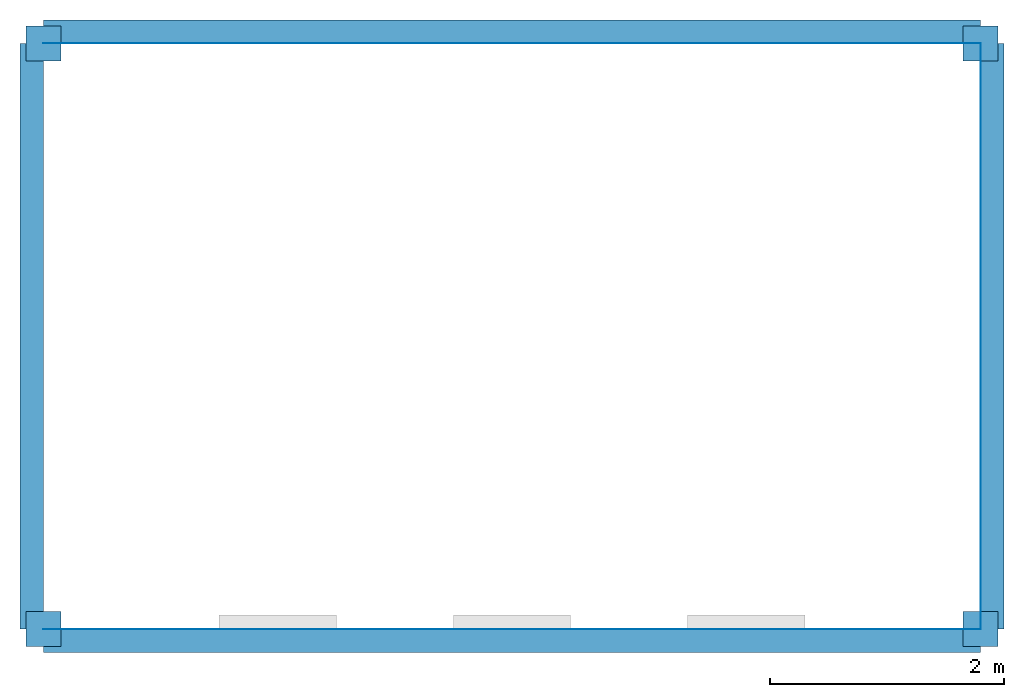
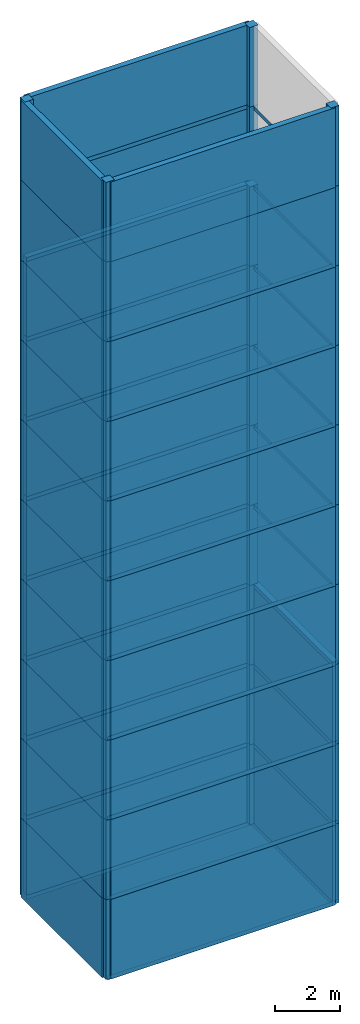
# Not in any storey, part 1 of 3: 40 columns, 33 walls, 10 slabs.
"""IFC4 model written with IfcOpenShell, lengths in metres."""

from ifc_helpers import new_model, si_unit, origin_with_axes, place, context, project, open_shell, faceted_brep, surface_model, element, save


model = new_model("IFC4")

# Units and contexts
model_context = context("Model", 3, precision=1e-05, world=origin_with_axes())
ifc_project = project(units=[si_unit("LENGTHUNIT", "METRE"), si_unit("AREAUNIT", "SQUARE_METRE"), si_unit("VOLUMEUNIT", "CUBIC_METRE")], contexts=[model_context])

# Columns
column_1_placement = place(None, origin_with_axes())
element("IfcColumn", 1, at=column_1_placement, context=model_context, shape_type="Brep", body=[
    faceted_brep([(-0.15, -0.15, 0.0), (-0.15, 0.15, 0.0), (0.15, 0.15, 0.0), (0.15, -0.15, 0.0), (-0.15, -0.15, 3.0), (0.15, -0.15, 3.0), (0.15, 0.15, 3.0), (-0.15, 0.15, 3.0)], [[[0, 1, 2, 3]], [[4, 5, 6, 7]], [[0, 3, 5, 4]], [[1, 7, 6, 2]], [[0, 4, 7, 1]], [[3, 2, 6, 5]]]),
])
column_2_placement = place(None, origin_with_axes())
element("IfcColumn", 2, at=column_2_placement, context=model_context, shape_type="Brep", body=[
    faceted_brep([(7.85, -0.15, 0.0), (7.85, 0.15, 0.0), (8.15, 0.15, 0.0), (8.15, -0.15, 0.0), (7.85, -0.15, 3.0), (8.15, -0.15, 3.0), (8.15, 0.15, 3.0), (7.85, 0.15, 3.0)], [[[0, 1, 2, 3]], [[4, 5, 6, 7]], [[0, 3, 5, 4]], [[1, 7, 6, 2]], [[0, 4, 7, 1]], [[3, 2, 6, 5]]]),
])
column_3_placement = place(None, origin_with_axes())
element("IfcColumn", 3, at=column_3_placement, context=model_context, shape_type="Brep", body=[
    faceted_brep([(7.85, 4.85, 0.0), (7.85, 5.15, 0.0), (8.15, 5.15, 0.0), (8.15, 4.85, 0.0), (7.85, 4.85, 3.0), (8.15, 4.85, 3.0), (8.15, 5.15, 3.0), (7.85, 5.15, 3.0)], [[[0, 1, 2, 3]], [[4, 5, 6, 7]], [[0, 3, 5, 4]], [[1, 7, 6, 2]], [[0, 4, 7, 1]], [[3, 2, 6, 5]]]),
])
column_4_placement = place(None, origin_with_axes())
element("IfcColumn", 4, at=column_4_placement, context=model_context, shape_type="Brep", body=[
    faceted_brep([(-0.15, 4.85, 0.0), (-0.15, 5.15, 0.0), (0.15, 5.15, 0.0), (0.15, 4.85, 0.0), (-0.15, 4.85, 3.0), (0.15, 4.85, 3.0), (0.15, 5.15, 3.0), (-0.15, 5.15, 3.0)], [[[0, 1, 2, 3]], [[4, 5, 6, 7]], [[0, 3, 5, 4]], [[1, 7, 6, 2]], [[0, 4, 7, 1]], [[3, 2, 6, 5]]]),
])
column_5_placement = place(None, origin_with_axes())
element("IfcColumn", 5, at=column_5_placement, context=model_context, shape_type="Brep", body=[
    faceted_brep([(-0.15, -0.15, 3.0), (-0.15, 0.15, 3.0), (0.15, 0.15, 3.0), (0.15, -0.15, 3.0), (-0.15, -0.15, 6.0), (0.15, -0.15, 6.0), (0.15, 0.15, 6.0), (-0.15, 0.15, 6.0)], [[[0, 1, 2, 3]], [[4, 5, 6, 7]], [[0, 3, 5, 4]], [[1, 7, 6, 2]], [[0, 4, 7, 1]], [[3, 2, 6, 5]]]),
])
column_6_placement = place(None, origin_with_axes())
element("IfcColumn", 6, at=column_6_placement, context=model_context, shape_type="Brep", body=[
    faceted_brep([(7.85, -0.15, 3.0), (7.85, 0.15, 3.0), (8.15, 0.15, 3.0), (8.15, -0.15, 3.0), (7.85, -0.15, 6.0), (8.15, -0.15, 6.0), (8.15, 0.15, 6.0), (7.85, 0.15, 6.0)], [[[0, 1, 2, 3]], [[4, 5, 6, 7]], [[0, 3, 5, 4]], [[1, 7, 6, 2]], [[0, 4, 7, 1]], [[3, 2, 6, 5]]]),
])
column_7_placement = place(None, origin_with_axes())
element("IfcColumn", 7, at=column_7_placement, context=model_context, shape_type="Brep", body=[
    faceted_brep([(7.85, 4.85, 3.0), (7.85, 5.15, 3.0), (8.15, 5.15, 3.0), (8.15, 4.85, 3.0), (7.85, 4.85, 6.0), (8.15, 4.85, 6.0), (8.15, 5.15, 6.0), (7.85, 5.15, 6.0)], [[[0, 1, 2, 3]], [[4, 5, 6, 7]], [[0, 3, 5, 4]], [[1, 7, 6, 2]], [[0, 4, 7, 1]], [[3, 2, 6, 5]]]),
])
column_8_placement = place(None, origin_with_axes())
element("IfcColumn", 8, at=column_8_placement, context=model_context, shape_type="Brep", body=[
    faceted_brep([(-0.15, 4.85, 3.0), (-0.15, 5.15, 3.0), (0.15, 5.15, 3.0), (0.15, 4.85, 3.0), (-0.15, 4.85, 6.0), (0.15, 4.85, 6.0), (0.15, 5.15, 6.0), (-0.15, 5.15, 6.0)], [[[0, 1, 2, 3]], [[4, 5, 6, 7]], [[0, 3, 5, 4]], [[1, 7, 6, 2]], [[0, 4, 7, 1]], [[3, 2, 6, 5]]]),
])
column_9_placement = place(None, origin_with_axes())
element("IfcColumn", 9, at=column_9_placement, context=model_context, shape_type="Brep", body=[
    faceted_brep([(-0.15, -0.15, 6.0), (-0.15, 0.15, 6.0), (0.15, 0.15, 6.0), (0.15, -0.15, 6.0), (-0.15, -0.15, 9.0), (0.15, -0.15, 9.0), (0.15, 0.15, 9.0), (-0.15, 0.15, 9.0)], [[[0, 1, 2, 3]], [[4, 5, 6, 7]], [[0, 3, 5, 4]], [[1, 7, 6, 2]], [[0, 4, 7, 1]], [[3, 2, 6, 5]]]),
])
column_10_placement = place(None, origin_with_axes())
element("IfcColumn", 10, at=column_10_placement, context=model_context, shape_type="Brep", body=[
    faceted_brep([(7.85, -0.15, 6.0), (7.85, 0.15, 6.0), (8.15, 0.15, 6.0), (8.15, -0.15, 6.0), (7.85, -0.15, 9.0), (8.15, -0.15, 9.0), (8.15, 0.15, 9.0), (7.85, 0.15, 9.0)], [[[0, 1, 2, 3]], [[4, 5, 6, 7]], [[0, 3, 5, 4]], [[1, 7, 6, 2]], [[0, 4, 7, 1]], [[3, 2, 6, 5]]]),
])
column_11_placement = place(None, origin_with_axes())
element("IfcColumn", 11, at=column_11_placement, context=model_context, shape_type="Brep", body=[
    faceted_brep([(7.85, 4.85, 6.0), (7.85, 5.15, 6.0), (8.15, 5.15, 6.0), (8.15, 4.85, 6.0), (7.85, 4.85, 9.0), (8.15, 4.85, 9.0), (8.15, 5.15, 9.0), (7.85, 5.15, 9.0)], [[[0, 1, 2, 3]], [[4, 5, 6, 7]], [[0, 3, 5, 4]], [[1, 7, 6, 2]], [[0, 4, 7, 1]], [[3, 2, 6, 5]]]),
])
column_12_placement = place(None, origin_with_axes())
element("IfcColumn", 12, at=column_12_placement, context=model_context, shape_type="Brep", body=[
    faceted_brep([(-0.15, 4.85, 6.0), (-0.15, 5.15, 6.0), (0.15, 5.15, 6.0), (0.15, 4.85, 6.0), (-0.15, 4.85, 9.0), (0.15, 4.85, 9.0), (0.15, 5.15, 9.0), (-0.15, 5.15, 9.0)], [[[0, 1, 2, 3]], [[4, 5, 6, 7]], [[0, 3, 5, 4]], [[1, 7, 6, 2]], [[0, 4, 7, 1]], [[3, 2, 6, 5]]]),
])
column_13_placement = place(None, origin_with_axes())
element("IfcColumn", 13, at=column_13_placement, context=model_context, shape_type="Brep", body=[
    faceted_brep([(-0.15, -0.15, 9.0), (-0.15, 0.15, 9.0), (0.15, 0.15, 9.0), (0.15, -0.15, 9.0), (-0.15, -0.15, 12.0), (0.15, -0.15, 12.0), (0.15, 0.15, 12.0), (-0.15, 0.15, 12.0)], [[[0, 1, 2, 3]], [[4, 5, 6, 7]], [[0, 3, 5, 4]], [[1, 7, 6, 2]], [[0, 4, 7, 1]], [[3, 2, 6, 5]]]),
])
column_14_placement = place(None, origin_with_axes())
element("IfcColumn", 14, at=column_14_placement, context=model_context, shape_type="Brep", body=[
    faceted_brep([(7.85, -0.15, 9.0), (7.85, 0.15, 9.0), (8.15, 0.15, 9.0), (8.15, -0.15, 9.0), (7.85, -0.15, 12.0), (8.15, -0.15, 12.0), (8.15, 0.15, 12.0), (7.85, 0.15, 12.0)], [[[0, 1, 2, 3]], [[4, 5, 6, 7]], [[0, 3, 5, 4]], [[1, 7, 6, 2]], [[0, 4, 7, 1]], [[3, 2, 6, 5]]]),
])
column_15_placement = place(None, origin_with_axes())
element("IfcColumn", 15, at=column_15_placement, context=model_context, shape_type="Brep", body=[
    faceted_brep([(7.85, 4.85, 9.0), (7.85, 5.15, 9.0), (8.15, 5.15, 9.0), (8.15, 4.85, 9.0), (7.85, 4.85, 12.0), (8.15, 4.85, 12.0), (8.15, 5.15, 12.0), (7.85, 5.15, 12.0)], [[[0, 1, 2, 3]], [[4, 5, 6, 7]], [[0, 3, 5, 4]], [[1, 7, 6, 2]], [[0, 4, 7, 1]], [[3, 2, 6, 5]]]),
])
column_16_placement = place(None, origin_with_axes())
element("IfcColumn", 16, at=column_16_placement, context=model_context, shape_type="Brep", body=[
    faceted_brep([(-0.15, 4.85, 9.0), (-0.15, 5.15, 9.0), (0.15, 5.15, 9.0), (0.15, 4.85, 9.0), (-0.15, 4.85, 12.0), (0.15, 4.85, 12.0), (0.15, 5.15, 12.0), (-0.15, 5.15, 12.0)], [[[0, 1, 2, 3]], [[4, 5, 6, 7]], [[0, 3, 5, 4]], [[1, 7, 6, 2]], [[0, 4, 7, 1]], [[3, 2, 6, 5]]]),
])
column_17_placement = place(None, origin_with_axes())
element("IfcColumn", 17, at=column_17_placement, context=model_context, shape_type="Brep", body=[
    faceted_brep([(-0.15, -0.15, 12.0), (-0.15, 0.15, 12.0), (0.15, 0.15, 12.0), (0.15, -0.15, 12.0), (-0.15, -0.15, 15.0), (0.15, -0.15, 15.0), (0.15, 0.15, 15.0), (-0.15, 0.15, 15.0)], [[[0, 1, 2, 3]], [[4, 5, 6, 7]], [[0, 3, 5, 4]], [[1, 7, 6, 2]], [[0, 4, 7, 1]], [[3, 2, 6, 5]]]),
])
column_18_placement = place(None, origin_with_axes())
element("IfcColumn", 18, at=column_18_placement, context=model_context, shape_type="Brep", body=[
    faceted_brep([(7.85, -0.15, 12.0), (7.85, 0.15, 12.0), (8.15, 0.15, 12.0), (8.15, -0.15, 12.0), (7.85, -0.15, 15.0), (8.15, -0.15, 15.0), (8.15, 0.15, 15.0), (7.85, 0.15, 15.0)], [[[0, 1, 2, 3]], [[4, 5, 6, 7]], [[0, 3, 5, 4]], [[1, 7, 6, 2]], [[0, 4, 7, 1]], [[3, 2, 6, 5]]]),
])
column_19_placement = place(None, origin_with_axes())
element("IfcColumn", 19, at=column_19_placement, context=model_context, shape_type="Brep", body=[
    faceted_brep([(7.85, 4.85, 12.0), (7.85, 5.15, 12.0), (8.15, 5.15, 12.0), (8.15, 4.85, 12.0), (7.85, 4.85, 15.0), (8.15, 4.85, 15.0), (8.15, 5.15, 15.0), (7.85, 5.15, 15.0)], [[[0, 1, 2, 3]], [[4, 5, 6, 7]], [[0, 3, 5, 4]], [[1, 7, 6, 2]], [[0, 4, 7, 1]], [[3, 2, 6, 5]]]),
])
column_20_placement = place(None, origin_with_axes())
element("IfcColumn", 20, at=column_20_placement, context=model_context, shape_type="Brep", body=[
    faceted_brep([(-0.15, 4.85, 12.0), (-0.15, 5.15, 12.0), (0.15, 5.15, 12.0), (0.15, 4.85, 12.0), (-0.15, 4.85, 15.0), (0.15, 4.85, 15.0), (0.15, 5.15, 15.0), (-0.15, 5.15, 15.0)], [[[0, 1, 2, 3]], [[4, 5, 6, 7]], [[0, 3, 5, 4]], [[1, 7, 6, 2]], [[0, 4, 7, 1]], [[3, 2, 6, 5]]]),
])
column_21_placement = place(None, origin_with_axes())
element("IfcColumn", 21, at=column_21_placement, context=model_context, shape_type="Brep", body=[
    faceted_brep([(-0.15, -0.15, 15.0), (-0.15, 0.15, 15.0), (0.15, 0.15, 15.0), (0.15, -0.15, 15.0), (-0.15, -0.15, 18.0), (0.15, -0.15, 18.0), (0.15, 0.15, 18.0), (-0.15, 0.15, 18.0)], [[[0, 1, 2, 3]], [[4, 5, 6, 7]], [[0, 3, 5, 4]], [[1, 7, 6, 2]], [[0, 4, 7, 1]], [[3, 2, 6, 5]]]),
])
column_22_placement = place(None, origin_with_axes())
element("IfcColumn", 22, at=column_22_placement, context=model_context, shape_type="Brep", body=[
    faceted_brep([(7.85, -0.15, 15.0), (7.85, 0.15, 15.0), (8.15, 0.15, 15.0), (8.15, -0.15, 15.0), (7.85, -0.15, 18.0), (8.15, -0.15, 18.0), (8.15, 0.15, 18.0), (7.85, 0.15, 18.0)], [[[0, 1, 2, 3]], [[4, 5, 6, 7]], [[0, 3, 5, 4]], [[1, 7, 6, 2]], [[0, 4, 7, 1]], [[3, 2, 6, 5]]]),
])
column_23_placement = place(None, origin_with_axes())
element("IfcColumn", 23, at=column_23_placement, context=model_context, shape_type="Brep", body=[
    faceted_brep([(7.85, 4.85, 15.0), (7.85, 5.15, 15.0), (8.15, 5.15, 15.0), (8.15, 4.85, 15.0), (7.85, 4.85, 18.0), (8.15, 4.85, 18.0), (8.15, 5.15, 18.0), (7.85, 5.15, 18.0)], [[[0, 1, 2, 3]], [[4, 5, 6, 7]], [[0, 3, 5, 4]], [[1, 7, 6, 2]], [[0, 4, 7, 1]], [[3, 2, 6, 5]]]),
])
column_24_placement = place(None, origin_with_axes())
element("IfcColumn", 24, at=column_24_placement, context=model_context, shape_type="Brep", body=[
    faceted_brep([(-0.15, 4.85, 15.0), (-0.15, 5.15, 15.0), (0.15, 5.15, 15.0), (0.15, 4.85, 15.0), (-0.15, 4.85, 18.0), (0.15, 4.85, 18.0), (0.15, 5.15, 18.0), (-0.15, 5.15, 18.0)], [[[0, 1, 2, 3]], [[4, 5, 6, 7]], [[0, 3, 5, 4]], [[1, 7, 6, 2]], [[0, 4, 7, 1]], [[3, 2, 6, 5]]]),
])
column_25_placement = place(None, origin_with_axes())
element("IfcColumn", 25, at=column_25_placement, context=model_context, shape_type="Brep", body=[
    faceted_brep([(-0.15, -0.15, 18.0), (-0.15, 0.15, 18.0), (0.15, 0.15, 18.0), (0.15, -0.15, 18.0), (-0.15, -0.15, 21.0), (0.15, -0.15, 21.0), (0.15, 0.15, 21.0), (-0.15, 0.15, 21.0)], [[[0, 1, 2, 3]], [[4, 5, 6, 7]], [[0, 3, 5, 4]], [[1, 7, 6, 2]], [[0, 4, 7, 1]], [[3, 2, 6, 5]]]),
])
column_26_placement = place(None, origin_with_axes())
element("IfcColumn", 26, at=column_26_placement, context=model_context, shape_type="Brep", body=[
    faceted_brep([(7.85, -0.15, 18.0), (7.85, 0.15, 18.0), (8.15, 0.15, 18.0), (8.15, -0.15, 18.0), (7.85, -0.15, 21.0), (8.15, -0.15, 21.0), (8.15, 0.15, 21.0), (7.85, 0.15, 21.0)], [[[0, 1, 2, 3]], [[4, 5, 6, 7]], [[0, 3, 5, 4]], [[1, 7, 6, 2]], [[0, 4, 7, 1]], [[3, 2, 6, 5]]]),
])
column_27_placement = place(None, origin_with_axes())
element("IfcColumn", 27, at=column_27_placement, context=model_context, shape_type="Brep", body=[
    faceted_brep([(7.85, 4.85, 18.0), (7.85, 5.15, 18.0), (8.15, 5.15, 18.0), (8.15, 4.85, 18.0), (7.85, 4.85, 21.0), (8.15, 4.85, 21.0), (8.15, 5.15, 21.0), (7.85, 5.15, 21.0)], [[[0, 1, 2, 3]], [[4, 5, 6, 7]], [[0, 3, 5, 4]], [[1, 7, 6, 2]], [[0, 4, 7, 1]], [[3, 2, 6, 5]]]),
])
column_28_placement = place(None, origin_with_axes())
element("IfcColumn", 28, at=column_28_placement, context=model_context, shape_type="Brep", body=[
    faceted_brep([(-0.15, 4.85, 18.0), (-0.15, 5.15, 18.0), (0.15, 5.15, 18.0), (0.15, 4.85, 18.0), (-0.15, 4.85, 21.0), (0.15, 4.85, 21.0), (0.15, 5.15, 21.0), (-0.15, 5.15, 21.0)], [[[0, 1, 2, 3]], [[4, 5, 6, 7]], [[0, 3, 5, 4]], [[1, 7, 6, 2]], [[0, 4, 7, 1]], [[3, 2, 6, 5]]]),
])
column_29_placement = place(None, origin_with_axes())
element("IfcColumn", 29, at=column_29_placement, context=model_context, shape_type="Brep", body=[
    faceted_brep([(-0.15, -0.15, 21.0), (-0.15, 0.15, 21.0), (0.15, 0.15, 21.0), (0.15, -0.15, 21.0), (-0.15, -0.15, 24.0), (0.15, -0.15, 24.0), (0.15, 0.15, 24.0), (-0.15, 0.15, 24.0)], [[[0, 1, 2, 3]], [[4, 5, 6, 7]], [[0, 3, 5, 4]], [[1, 7, 6, 2]], [[0, 4, 7, 1]], [[3, 2, 6, 5]]]),
])
column_30_placement = place(None, origin_with_axes())
element("IfcColumn", 30, at=column_30_placement, context=model_context, shape_type="Brep", body=[
    faceted_brep([(7.85, -0.15, 21.0), (7.85, 0.15, 21.0), (8.15, 0.15, 21.0), (8.15, -0.15, 21.0), (7.85, -0.15, 24.0), (8.15, -0.15, 24.0), (8.15, 0.15, 24.0), (7.85, 0.15, 24.0)], [[[0, 1, 2, 3]], [[4, 5, 6, 7]], [[0, 3, 5, 4]], [[1, 7, 6, 2]], [[0, 4, 7, 1]], [[3, 2, 6, 5]]]),
])
column_31_placement = place(None, origin_with_axes())
element("IfcColumn", 31, at=column_31_placement, context=model_context, shape_type="Brep", body=[
    faceted_brep([(7.85, 4.85, 21.0), (7.85, 5.15, 21.0), (8.15, 5.15, 21.0), (8.15, 4.85, 21.0), (7.85, 4.85, 24.0), (8.15, 4.85, 24.0), (8.15, 5.15, 24.0), (7.85, 5.15, 24.0)], [[[0, 1, 2, 3]], [[4, 5, 6, 7]], [[0, 3, 5, 4]], [[1, 7, 6, 2]], [[0, 4, 7, 1]], [[3, 2, 6, 5]]]),
])
column_32_placement = place(None, origin_with_axes())
element("IfcColumn", 32, at=column_32_placement, context=model_context, shape_type="Brep", body=[
    faceted_brep([(-0.15, 4.85, 21.0), (-0.15, 5.15, 21.0), (0.15, 5.15, 21.0), (0.15, 4.85, 21.0), (-0.15, 4.85, 24.0), (0.15, 4.85, 24.0), (0.15, 5.15, 24.0), (-0.15, 5.15, 24.0)], [[[0, 1, 2, 3]], [[4, 5, 6, 7]], [[0, 3, 5, 4]], [[1, 7, 6, 2]], [[0, 4, 7, 1]], [[3, 2, 6, 5]]]),
])
column_33_placement = place(None, origin_with_axes())
element("IfcColumn", 33, at=column_33_placement, context=model_context, shape_type="Brep", body=[
    faceted_brep([(-0.15, -0.15, 24.0), (-0.15, 0.15, 24.0), (0.15, 0.15, 24.0), (0.15, -0.15, 24.0), (-0.15, -0.15, 27.0), (0.15, -0.15, 27.0), (0.15, 0.15, 27.0), (-0.15, 0.15, 27.0)], [[[0, 1, 2, 3]], [[4, 5, 6, 7]], [[0, 3, 5, 4]], [[1, 7, 6, 2]], [[0, 4, 7, 1]], [[3, 2, 6, 5]]]),
])
column_34_placement = place(None, origin_with_axes())
element("IfcColumn", 34, at=column_34_placement, context=model_context, shape_type="Brep", body=[
    faceted_brep([(7.85, -0.15, 24.0), (7.85, 0.15, 24.0), (8.15, 0.15, 24.0), (8.15, -0.15, 24.0), (7.85, -0.15, 27.0), (8.15, -0.15, 27.0), (8.15, 0.15, 27.0), (7.85, 0.15, 27.0)], [[[0, 1, 2, 3]], [[4, 5, 6, 7]], [[0, 3, 5, 4]], [[1, 7, 6, 2]], [[0, 4, 7, 1]], [[3, 2, 6, 5]]]),
])
column_35_placement = place(None, origin_with_axes())
element("IfcColumn", 35, at=column_35_placement, context=model_context, shape_type="Brep", body=[
    faceted_brep([(7.85, 4.85, 24.0), (7.85, 5.15, 24.0), (8.15, 5.15, 24.0), (8.15, 4.85, 24.0), (7.85, 4.85, 27.0), (8.15, 4.85, 27.0), (8.15, 5.15, 27.0), (7.85, 5.15, 27.0)], [[[0, 1, 2, 3]], [[4, 5, 6, 7]], [[0, 3, 5, 4]], [[1, 7, 6, 2]], [[0, 4, 7, 1]], [[3, 2, 6, 5]]]),
])
column_36_placement = place(None, origin_with_axes())
element("IfcColumn", 36, at=column_36_placement, context=model_context, shape_type="Brep", body=[
    faceted_brep([(-0.15, 4.85, 24.0), (-0.15, 5.15, 24.0), (0.15, 5.15, 24.0), (0.15, 4.85, 24.0), (-0.15, 4.85, 27.0), (0.15, 4.85, 27.0), (0.15, 5.15, 27.0), (-0.15, 5.15, 27.0)], [[[0, 1, 2, 3]], [[4, 5, 6, 7]], [[0, 3, 5, 4]], [[1, 7, 6, 2]], [[0, 4, 7, 1]], [[3, 2, 6, 5]]]),
])
column_37_placement = place(None, origin_with_axes())
element("IfcColumn", 37, at=column_37_placement, context=model_context, shape_type="Brep", body=[
    faceted_brep([(-0.15, -0.15, 27.0), (-0.15, 0.15, 27.0), (0.15, 0.15, 27.0), (0.15, -0.15, 27.0), (-0.15, -0.15, 30.0), (0.15, -0.15, 30.0), (0.15, 0.15, 30.0), (-0.15, 0.15, 30.0)], [[[0, 1, 2, 3]], [[4, 5, 6, 7]], [[0, 3, 5, 4]], [[1, 7, 6, 2]], [[0, 4, 7, 1]], [[3, 2, 6, 5]]]),
])
column_38_placement = place(None, origin_with_axes())
element("IfcColumn", 38, at=column_38_placement, context=model_context, shape_type="Brep", body=[
    faceted_brep([(7.85, -0.15, 27.0), (7.85, 0.15, 27.0), (8.15, 0.15, 27.0), (8.15, -0.15, 27.0), (7.85, -0.15, 30.0), (8.15, -0.15, 30.0), (8.15, 0.15, 30.0), (7.85, 0.15, 30.0)], [[[0, 1, 2, 3]], [[4, 5, 6, 7]], [[0, 3, 5, 4]], [[1, 7, 6, 2]], [[0, 4, 7, 1]], [[3, 2, 6, 5]]]),
])
column_39_placement = place(None, origin_with_axes())
element("IfcColumn", 39, at=column_39_placement, context=model_context, shape_type="Brep", body=[
    faceted_brep([(7.85, 4.85, 27.0), (7.85, 5.15, 27.0), (8.15, 5.15, 27.0), (8.15, 4.85, 27.0), (7.85, 4.85, 30.0), (8.15, 4.85, 30.0), (8.15, 5.15, 30.0), (7.85, 5.15, 30.0)], [[[0, 1, 2, 3]], [[4, 5, 6, 7]], [[0, 3, 5, 4]], [[1, 7, 6, 2]], [[0, 4, 7, 1]], [[3, 2, 6, 5]]]),
])
column_40_placement = place(None, origin_with_axes())
element("IfcColumn", 40, at=column_40_placement, context=model_context, shape_type="Brep", body=[
    faceted_brep([(-0.15, 4.85, 27.0), (-0.15, 5.15, 27.0), (0.15, 5.15, 27.0), (0.15, 4.85, 27.0), (-0.15, 4.85, 30.0), (0.15, 4.85, 30.0), (0.15, 5.15, 30.0), (-0.15, 5.15, 30.0)], [[[0, 1, 2, 3]], [[4, 5, 6, 7]], [[0, 3, 5, 4]], [[1, 7, 6, 2]], [[0, 4, 7, 1]], [[3, 2, 6, 5]]]),
])

# Slabs
slab_1_placement = place(None, origin_with_axes())
element("IfcSlab", 41, at=slab_1_placement, context=model_context, shape_type="SurfaceModel", body=[
    surface_model("IfcShellBasedSurfaceModel", [(0.0, 0.0, 0.0), (8.0, 0.0, 0.0), (8.0, 0.0, -0.15), (0.0, 0.0, -0.15), (8.0, 0.0, 0.0), (8.0, 5.0, 0.0), (8.0, 5.0, -0.15), (8.0, 0.0, -0.15), (8.0, 5.0, 0.0), (0.0, 5.0, 0.0), (0.0, 5.0, -0.15), (8.0, 5.0, -0.15)], [open_shell([[[0, 1, 2, 3]], [[4, 5, 6, 7]], [[8, 9, 10, 11]]])]),
])
slab_2_placement = place(None, origin_with_axes())
element("IfcSlab", 42, at=slab_2_placement, context=model_context, shape_type="SurfaceModel", body=[
    surface_model("IfcShellBasedSurfaceModel", [(0.0, 0.0, 3.0), (8.0, 0.0, 3.0), (8.0, 0.0, 2.85), (0.0, 0.0, 2.85), (8.0, 0.0, 3.0), (8.0, 5.0, 3.0), (8.0, 5.0, 2.85), (8.0, 0.0, 2.85), (8.0, 5.0, 3.0), (0.0, 5.0, 3.0), (0.0, 5.0, 2.85), (8.0, 5.0, 2.85)], [open_shell([[[0, 1, 2, 3]], [[4, 5, 6, 7]], [[8, 9, 10, 11]]])]),
])
slab_3_placement = place(None, origin_with_axes())
element("IfcSlab", 43, at=slab_3_placement, context=model_context, shape_type="SurfaceModel", body=[
    surface_model("IfcShellBasedSurfaceModel", [(0.0, 0.0, 6.0), (8.0, 0.0, 6.0), (8.0, 0.0, 5.85), (0.0, 0.0, 5.85), (8.0, 0.0, 6.0), (8.0, 5.0, 6.0), (8.0, 5.0, 5.85), (8.0, 0.0, 5.85), (8.0, 5.0, 6.0), (0.0, 5.0, 6.0), (0.0, 5.0, 5.85), (8.0, 5.0, 5.85)], [open_shell([[[0, 1, 2, 3]], [[4, 5, 6, 7]], [[8, 9, 10, 11]]])]),
])
slab_4_placement = place(None, origin_with_axes())
element("IfcSlab", 44, at=slab_4_placement, context=model_context, shape_type="SurfaceModel", body=[
    surface_model("IfcShellBasedSurfaceModel", [(0.0, 0.0, 9.0), (8.0, 0.0, 9.0), (8.0, 0.0, 8.85), (0.0, 0.0, 8.85), (8.0, 0.0, 9.0), (8.0, 5.0, 9.0), (8.0, 5.0, 8.85), (8.0, 0.0, 8.85), (8.0, 5.0, 9.0), (0.0, 5.0, 9.0), (0.0, 5.0, 8.85), (8.0, 5.0, 8.85)], [open_shell([[[0, 1, 2, 3]], [[4, 5, 6, 7]], [[8, 9, 10, 11]]])]),
])
slab_5_placement = place(None, origin_with_axes())
element("IfcSlab", 45, at=slab_5_placement, context=model_context, shape_type="SurfaceModel", body=[
    surface_model("IfcShellBasedSurfaceModel", [(0.0, 0.0, 12.0), (8.0, 0.0, 12.0), (8.0, 0.0, 11.85), (0.0, 0.0, 11.85), (8.0, 0.0, 12.0), (8.0, 5.0, 12.0), (8.0, 5.0, 11.85), (8.0, 0.0, 11.85), (8.0, 5.0, 12.0), (0.0, 5.0, 12.0), (0.0, 5.0, 11.85), (8.0, 5.0, 11.85)], [open_shell([[[0, 1, 2, 3]], [[4, 5, 6, 7]], [[8, 9, 10, 11]]])]),
])
slab_6_placement = place(None, origin_with_axes())
element("IfcSlab", 46, at=slab_6_placement, context=model_context, shape_type="SurfaceModel", body=[
    surface_model("IfcShellBasedSurfaceModel", [(0.0, 0.0, 15.0), (8.0, 0.0, 15.0), (8.0, 0.0, 14.85), (0.0, 0.0, 14.85), (8.0, 0.0, 15.0), (8.0, 5.0, 15.0), (8.0, 5.0, 14.85), (8.0, 0.0, 14.85), (8.0, 5.0, 15.0), (0.0, 5.0, 15.0), (0.0, 5.0, 14.85), (8.0, 5.0, 14.85)], [open_shell([[[0, 1, 2, 3]], [[4, 5, 6, 7]], [[8, 9, 10, 11]]])]),
])
slab_7_placement = place(None, origin_with_axes())
element("IfcSlab", 47, at=slab_7_placement, context=model_context, shape_type="SurfaceModel", body=[
    surface_model("IfcShellBasedSurfaceModel", [(0.0, 0.0, 18.0), (8.0, 0.0, 18.0), (8.0, 0.0, 17.85), (0.0, 0.0, 17.85), (8.0, 0.0, 18.0), (8.0, 5.0, 18.0), (8.0, 5.0, 17.85), (8.0, 0.0, 17.85), (8.0, 5.0, 18.0), (0.0, 5.0, 18.0), (0.0, 5.0, 17.85), (8.0, 5.0, 17.85)], [open_shell([[[0, 1, 2, 3]], [[4, 5, 6, 7]], [[8, 9, 10, 11]]])]),
])
slab_8_placement = place(None, origin_with_axes())
element("IfcSlab", 48, at=slab_8_placement, context=model_context, shape_type="SurfaceModel", body=[
    surface_model("IfcShellBasedSurfaceModel", [(0.0, 0.0, 21.0), (8.0, 0.0, 21.0), (8.0, 0.0, 20.85), (0.0, 0.0, 20.85), (8.0, 0.0, 21.0), (8.0, 5.0, 21.0), (8.0, 5.0, 20.85), (8.0, 0.0, 20.85), (8.0, 5.0, 21.0), (0.0, 5.0, 21.0), (0.0, 5.0, 20.85), (8.0, 5.0, 20.85)], [open_shell([[[0, 1, 2, 3]], [[4, 5, 6, 7]], [[8, 9, 10, 11]]])]),
])
slab_9_placement = place(None, origin_with_axes())
element("IfcSlab", 49, at=slab_9_placement, context=model_context, shape_type="SurfaceModel", body=[
    surface_model("IfcShellBasedSurfaceModel", [(0.0, 0.0, 24.0), (8.0, 0.0, 24.0), (8.0, 0.0, 23.85), (0.0, 0.0, 23.85), (8.0, 0.0, 24.0), (8.0, 5.0, 24.0), (8.0, 5.0, 23.85), (8.0, 0.0, 23.85), (8.0, 5.0, 24.0), (0.0, 5.0, 24.0), (0.0, 5.0, 23.85), (8.0, 5.0, 23.85)], [open_shell([[[0, 1, 2, 3]], [[4, 5, 6, 7]], [[8, 9, 10, 11]]])]),
])
slab_10_placement = place(None, origin_with_axes())
element("IfcSlab", 50, at=slab_10_placement, context=model_context, shape_type="SurfaceModel", body=[
    surface_model("IfcShellBasedSurfaceModel", [(0.0, 0.0, 27.0), (8.0, 0.0, 27.0), (8.0, 0.0, 26.85), (0.0, 0.0, 26.85), (8.0, 0.0, 27.0), (8.0, 5.0, 27.0), (8.0, 5.0, 26.85), (8.0, 0.0, 26.85), (8.0, 5.0, 27.0), (0.0, 5.0, 27.0), (0.0, 5.0, 26.85), (8.0, 5.0, 26.85)], [open_shell([[[0, 1, 2, 3]], [[4, 5, 6, 7]], [[8, 9, 10, 11]]])]),
])

# Walls
wall_1_placement = place(None, origin_with_axes())
element("IfcWall", 51, at=wall_1_placement, context=model_context, shape_type="Brep", body=[
    faceted_brep([(0.0, 0.0, 0.0), (0.0, -0.2, 0.0), (8.0, -0.2, 0.0), (8.0, 0.0, 0.0), (0.0, 0.0, 3.0), (8.0, 0.0, 3.0), (8.0, -0.2, 3.0), (0.0, -0.2, 3.0)], [[[0, 1, 2, 3]], [[4, 5, 6, 7]], [[0, 3, 5, 4]], [[1, 7, 6, 2]], [[0, 4, 7, 1]], [[3, 2, 6, 5]]]),
])
wall_2_placement = place(None, origin_with_axes())
element("IfcWall", 52, at=wall_2_placement, context=model_context, shape_type="Brep", body=[
    faceted_brep([(8.0, 0.0, 0.0), (8.2, 0.0, 0.0), (8.2, 5.0, 0.0), (8.0, 5.0, 0.0), (8.0, 0.0, 3.0), (8.0, 5.0, 3.0), (8.2, 5.0, 3.0), (8.2, 0.0, 3.0)], [[[0, 1, 2, 3]], [[4, 5, 6, 7]], [[0, 3, 5, 4]], [[1, 7, 6, 2]], [[0, 4, 7, 1]], [[3, 2, 6, 5]]]),
])
wall_3_placement = place(None, origin_with_axes())
element("IfcWall", 53, at=wall_3_placement, context=model_context, shape_type="Brep", body=[
    faceted_brep([(8.0, 5.0, 0.0), (8.0, 5.2, 0.0), (0.0, 5.2, 0.0), (0.0, 5.0, 0.0), (8.0, 5.0, 3.0), (0.0, 5.0, 3.0), (0.0, 5.2, 3.0), (8.0, 5.2, 3.0)], [[[0, 1, 2, 3]], [[4, 5, 6, 7]], [[0, 3, 5, 4]], [[1, 7, 6, 2]], [[0, 4, 7, 1]], [[3, 2, 6, 5]]]),
])
wall_4_placement = place(None, origin_with_axes())
element("IfcWall", 54, at=wall_4_placement, context=model_context, shape_type="Brep", body=[
    faceted_brep([(0.0, 5.0, 0.0), (-0.2, 5.0, 0.0), (-0.2, 0.0, 0.0), (0.0, 0.0, 0.0), (0.0, 5.0, 3.0), (0.0, 0.0, 3.0), (-0.2, 0.0, 3.0), (-0.2, 5.0, 3.0)], [[[0, 1, 2, 3]], [[4, 5, 6, 7]], [[0, 3, 5, 4]], [[1, 7, 6, 2]], [[0, 4, 7, 1]], [[3, 2, 6, 5]]]),
])
wall_5_placement = place(None, origin_with_axes())
element("IfcWall", 55, at=wall_5_placement, context=model_context, shape_type="Brep", body=[
    faceted_brep([(0.0, 0.0, 3.0), (0.0, -0.2, 3.0), (8.0, -0.2, 3.0), (8.0, 0.0, 3.0), (0.0, 0.0, 6.0), (8.0, 0.0, 6.0), (8.0, -0.2, 6.0), (0.0, -0.2, 6.0)], [[[0, 1, 2, 3]], [[4, 5, 6, 7]], [[0, 3, 5, 4]], [[1, 7, 6, 2]], [[0, 4, 7, 1]], [[3, 2, 6, 5]]]),
])
wall_6_placement = place(None, origin_with_axes())
element("IfcWall", 56, at=wall_6_placement, context=model_context, shape_type="Brep", body=[
    faceted_brep([(8.0, 0.0, 3.0), (8.2, 0.0, 3.0), (8.2, 5.0, 3.0), (8.0, 5.0, 3.0), (8.0, 0.0, 6.0), (8.0, 5.0, 6.0), (8.2, 5.0, 6.0), (8.2, 0.0, 6.0)], [[[0, 1, 2, 3]], [[4, 5, 6, 7]], [[0, 3, 5, 4]], [[1, 7, 6, 2]], [[0, 4, 7, 1]], [[3, 2, 6, 5]]]),
])
wall_7_placement = place(None, origin_with_axes())
element("IfcWall", 57, at=wall_7_placement, context=model_context, shape_type="Brep", body=[
    faceted_brep([(8.0, 5.0, 3.0), (8.0, 5.2, 3.0), (0.0, 5.2, 3.0), (0.0, 5.0, 3.0), (8.0, 5.0, 6.0), (0.0, 5.0, 6.0), (0.0, 5.2, 6.0), (8.0, 5.2, 6.0)], [[[0, 1, 2, 3]], [[4, 5, 6, 7]], [[0, 3, 5, 4]], [[1, 7, 6, 2]], [[0, 4, 7, 1]], [[3, 2, 6, 5]]]),
])
wall_8_placement = place(None, origin_with_axes())
element("IfcWall", 58, at=wall_8_placement, context=model_context, shape_type="Brep", body=[
    faceted_brep([(0.0, 5.0, 3.0), (-0.2, 5.0, 3.0), (-0.2, 0.0, 3.0), (0.0, 0.0, 3.0), (0.0, 5.0, 6.0), (0.0, 0.0, 6.0), (-0.2, 0.0, 6.0), (-0.2, 5.0, 6.0)], [[[0, 1, 2, 3]], [[4, 5, 6, 7]], [[0, 3, 5, 4]], [[1, 7, 6, 2]], [[0, 4, 7, 1]], [[3, 2, 6, 5]]]),
])
wall_9_placement = place(None, origin_with_axes())
element("IfcWall", 59, at=wall_9_placement, context=model_context, shape_type="Brep", body=[
    faceted_brep([(0.0, 0.0, 6.0), (0.0, -0.2, 6.0), (8.0, -0.2, 6.0), (8.0, 0.0, 6.0), (0.0, 0.0, 9.0), (8.0, 0.0, 9.0), (8.0, -0.2, 9.0), (0.0, -0.2, 9.0)], [[[0, 1, 2, 3]], [[4, 5, 6, 7]], [[0, 3, 5, 4]], [[1, 7, 6, 2]], [[0, 4, 7, 1]], [[3, 2, 6, 5]]]),
])
wall_10_placement = place(None, origin_with_axes())
element("IfcWall", 60, at=wall_10_placement, context=model_context, shape_type="Brep", body=[
    faceted_brep([(8.0, 0.0, 6.0), (8.2, 0.0, 6.0), (8.2, 5.0, 6.0), (8.0, 5.0, 6.0), (8.0, 0.0, 9.0), (8.0, 5.0, 9.0), (8.2, 5.0, 9.0), (8.2, 0.0, 9.0)], [[[0, 1, 2, 3]], [[4, 5, 6, 7]], [[0, 3, 5, 4]], [[1, 7, 6, 2]], [[0, 4, 7, 1]], [[3, 2, 6, 5]]]),
])
wall_11_placement = place(None, origin_with_axes())
element("IfcWall", 61, at=wall_11_placement, context=model_context, shape_type="Brep", body=[
    faceted_brep([(8.0, 5.0, 6.0), (8.0, 5.2, 6.0), (0.0, 5.2, 6.0), (0.0, 5.0, 6.0), (8.0, 5.0, 9.0), (0.0, 5.0, 9.0), (0.0, 5.2, 9.0), (8.0, 5.2, 9.0)], [[[0, 1, 2, 3]], [[4, 5, 6, 7]], [[0, 3, 5, 4]], [[1, 7, 6, 2]], [[0, 4, 7, 1]], [[3, 2, 6, 5]]]),
])
wall_12_placement = place(None, origin_with_axes())
element("IfcWall", 62, at=wall_12_placement, context=model_context, shape_type="Brep", body=[
    faceted_brep([(0.0, 5.0, 6.0), (-0.2, 5.0, 6.0), (-0.2, 0.0, 6.0), (0.0, 0.0, 6.0), (0.0, 5.0, 9.0), (0.0, 0.0, 9.0), (-0.2, 0.0, 9.0), (-0.2, 5.0, 9.0)], [[[0, 1, 2, 3]], [[4, 5, 6, 7]], [[0, 3, 5, 4]], [[1, 7, 6, 2]], [[0, 4, 7, 1]], [[3, 2, 6, 5]]]),
])
wall_13_placement = place(None, origin_with_axes())
element("IfcWall", 63, at=wall_13_placement, context=model_context, shape_type="Brep", body=[
    faceted_brep([(0.0, 0.0, 9.0), (0.0, -0.2, 9.0), (8.0, -0.2, 9.0), (8.0, 0.0, 9.0), (0.0, 0.0, 12.0), (8.0, 0.0, 12.0), (8.0, -0.2, 12.0), (0.0, -0.2, 12.0)], [[[0, 1, 2, 3]], [[4, 5, 6, 7]], [[0, 3, 5, 4]], [[1, 7, 6, 2]], [[0, 4, 7, 1]], [[3, 2, 6, 5]]]),
])
wall_14_placement = place(None, origin_with_axes())
element("IfcWall", 64, at=wall_14_placement, context=model_context, shape_type="Brep", body=[
    faceted_brep([(8.0, 5.0, 9.0), (8.0, 5.2, 9.0), (0.0, 5.2, 9.0), (0.0, 5.0, 9.0), (8.0, 5.0, 12.0), (0.0, 5.0, 12.0), (0.0, 5.2, 12.0), (8.0, 5.2, 12.0)], [[[0, 1, 2, 3]], [[4, 5, 6, 7]], [[0, 3, 5, 4]], [[1, 7, 6, 2]], [[0, 4, 7, 1]], [[3, 2, 6, 5]]]),
])
wall_15_placement = place(None, origin_with_axes())
element("IfcWall", 65, at=wall_15_placement, context=model_context, shape_type="Brep", body=[
    faceted_brep([(0.0, 5.0, 9.0), (-0.2, 5.0, 9.0), (-0.2, 0.0, 9.0), (0.0, 0.0, 9.0), (0.0, 5.0, 12.0), (0.0, 0.0, 12.0), (-0.2, 0.0, 12.0), (-0.2, 5.0, 12.0)], [[[0, 1, 2, 3]], [[4, 5, 6, 7]], [[0, 3, 5, 4]], [[1, 7, 6, 2]], [[0, 4, 7, 1]], [[3, 2, 6, 5]]]),
])
wall_16_placement = place(None, origin_with_axes())
element("IfcWall", 66, at=wall_16_placement, context=model_context, shape_type="Brep", body=[
    faceted_brep([(0.0, 0.0, 12.0), (0.0, -0.2, 12.0), (8.0, -0.2, 12.0), (8.0, 0.0, 12.0), (0.0, 0.0, 15.0), (8.0, 0.0, 15.0), (8.0, -0.2, 15.0), (0.0, -0.2, 15.0)], [[[0, 1, 2, 3]], [[4, 5, 6, 7]], [[0, 3, 5, 4]], [[1, 7, 6, 2]], [[0, 4, 7, 1]], [[3, 2, 6, 5]]]),
])
wall_17_placement = place(None, origin_with_axes())
element("IfcWall", 67, at=wall_17_placement, context=model_context, shape_type="Brep", body=[
    faceted_brep([(8.0, 5.0, 12.0), (8.0, 5.2, 12.0), (0.0, 5.2, 12.0), (0.0, 5.0, 12.0), (8.0, 5.0, 15.0), (0.0, 5.0, 15.0), (0.0, 5.2, 15.0), (8.0, 5.2, 15.0)], [[[0, 1, 2, 3]], [[4, 5, 6, 7]], [[0, 3, 5, 4]], [[1, 7, 6, 2]], [[0, 4, 7, 1]], [[3, 2, 6, 5]]]),
])
wall_18_placement = place(None, origin_with_axes())
element("IfcWall", 68, at=wall_18_placement, context=model_context, shape_type="Brep", body=[
    faceted_brep([(0.0, 5.0, 12.0), (-0.2, 5.0, 12.0), (-0.2, 0.0, 12.0), (0.0, 0.0, 12.0), (0.0, 5.0, 15.0), (0.0, 0.0, 15.0), (-0.2, 0.0, 15.0), (-0.2, 5.0, 15.0)], [[[0, 1, 2, 3]], [[4, 5, 6, 7]], [[0, 3, 5, 4]], [[1, 7, 6, 2]], [[0, 4, 7, 1]], [[3, 2, 6, 5]]]),
])
wall_19_placement = place(None, origin_with_axes())
element("IfcWall", 69, at=wall_19_placement, context=model_context, shape_type="Brep", body=[
    faceted_brep([(0.0, 0.0, 15.0), (0.0, -0.2, 15.0), (8.0, -0.2, 15.0), (8.0, 0.0, 15.0), (0.0, 0.0, 18.0), (8.0, 0.0, 18.0), (8.0, -0.2, 18.0), (0.0, -0.2, 18.0)], [[[0, 1, 2, 3]], [[4, 5, 6, 7]], [[0, 3, 5, 4]], [[1, 7, 6, 2]], [[0, 4, 7, 1]], [[3, 2, 6, 5]]]),
])
wall_20_placement = place(None, origin_with_axes())
element("IfcWall", 70, at=wall_20_placement, context=model_context, shape_type="Brep", body=[
    faceted_brep([(8.0, 5.0, 15.0), (8.0, 5.2, 15.0), (0.0, 5.2, 15.0), (0.0, 5.0, 15.0), (8.0, 5.0, 18.0), (0.0, 5.0, 18.0), (0.0, 5.2, 18.0), (8.0, 5.2, 18.0)], [[[0, 1, 2, 3]], [[4, 5, 6, 7]], [[0, 3, 5, 4]], [[1, 7, 6, 2]], [[0, 4, 7, 1]], [[3, 2, 6, 5]]]),
])
wall_21_placement = place(None, origin_with_axes())
element("IfcWall", 71, at=wall_21_placement, context=model_context, shape_type="Brep", body=[
    faceted_brep([(0.0, 5.0, 15.0), (-0.2, 5.0, 15.0), (-0.2, 0.0, 15.0), (0.0, 0.0, 15.0), (0.0, 5.0, 18.0), (0.0, 0.0, 18.0), (-0.2, 0.0, 18.0), (-0.2, 5.0, 18.0)], [[[0, 1, 2, 3]], [[4, 5, 6, 7]], [[0, 3, 5, 4]], [[1, 7, 6, 2]], [[0, 4, 7, 1]], [[3, 2, 6, 5]]]),
])
wall_22_placement = place(None, origin_with_axes())
element("IfcWall", 72, at=wall_22_placement, context=model_context, shape_type="Brep", body=[
    faceted_brep([(0.0, 0.0, 18.0), (0.0, -0.2, 18.0), (8.0, -0.2, 18.0), (8.0, 0.0, 18.0), (0.0, 0.0, 21.0), (8.0, 0.0, 21.0), (8.0, -0.2, 21.0), (0.0, -0.2, 21.0)], [[[0, 1, 2, 3]], [[4, 5, 6, 7]], [[0, 3, 5, 4]], [[1, 7, 6, 2]], [[0, 4, 7, 1]], [[3, 2, 6, 5]]]),
])
wall_23_placement = place(None, origin_with_axes())
element("IfcWall", 73, at=wall_23_placement, context=model_context, shape_type="Brep", body=[
    faceted_brep([(8.0, 5.0, 18.0), (8.0, 5.2, 18.0), (0.0, 5.2, 18.0), (0.0, 5.0, 18.0), (8.0, 5.0, 21.0), (0.0, 5.0, 21.0), (0.0, 5.2, 21.0), (8.0, 5.2, 21.0)], [[[0, 1, 2, 3]], [[4, 5, 6, 7]], [[0, 3, 5, 4]], [[1, 7, 6, 2]], [[0, 4, 7, 1]], [[3, 2, 6, 5]]]),
])
wall_24_placement = place(None, origin_with_axes())
element("IfcWall", 74, at=wall_24_placement, context=model_context, shape_type="Brep", body=[
    faceted_brep([(0.0, 5.0, 18.0), (-0.2, 5.0, 18.0), (-0.2, 0.0, 18.0), (0.0, 0.0, 18.0), (0.0, 5.0, 21.0), (0.0, 0.0, 21.0), (-0.2, 0.0, 21.0), (-0.2, 5.0, 21.0)], [[[0, 1, 2, 3]], [[4, 5, 6, 7]], [[0, 3, 5, 4]], [[1, 7, 6, 2]], [[0, 4, 7, 1]], [[3, 2, 6, 5]]]),
])
wall_25_placement = place(None, origin_with_axes())
element("IfcWall", 75, at=wall_25_placement, context=model_context, shape_type="Brep", body=[
    faceted_brep([(0.0, 0.0, 21.0), (0.0, -0.2, 21.0), (8.0, -0.2, 21.0), (8.0, 0.0, 21.0), (0.0, 0.0, 24.0), (8.0, 0.0, 24.0), (8.0, -0.2, 24.0), (0.0, -0.2, 24.0)], [[[0, 1, 2, 3]], [[4, 5, 6, 7]], [[0, 3, 5, 4]], [[1, 7, 6, 2]], [[0, 4, 7, 1]], [[3, 2, 6, 5]]]),
])
wall_26_placement = place(None, origin_with_axes())
element("IfcWall", 76, at=wall_26_placement, context=model_context, shape_type="Brep", body=[
    faceted_brep([(8.0, 5.0, 21.0), (8.0, 5.2, 21.0), (0.0, 5.2, 21.0), (0.0, 5.0, 21.0), (8.0, 5.0, 24.0), (0.0, 5.0, 24.0), (0.0, 5.2, 24.0), (8.0, 5.2, 24.0)], [[[0, 1, 2, 3]], [[4, 5, 6, 7]], [[0, 3, 5, 4]], [[1, 7, 6, 2]], [[0, 4, 7, 1]], [[3, 2, 6, 5]]]),
])
wall_27_placement = place(None, origin_with_axes())
element("IfcWall", 77, at=wall_27_placement, context=model_context, shape_type="Brep", body=[
    faceted_brep([(0.0, 5.0, 21.0), (-0.2, 5.0, 21.0), (-0.2, 0.0, 21.0), (0.0, 0.0, 21.0), (0.0, 5.0, 24.0), (0.0, 0.0, 24.0), (-0.2, 0.0, 24.0), (-0.2, 5.0, 24.0)], [[[0, 1, 2, 3]], [[4, 5, 6, 7]], [[0, 3, 5, 4]], [[1, 7, 6, 2]], [[0, 4, 7, 1]], [[3, 2, 6, 5]]]),
])
wall_28_placement = place(None, origin_with_axes())
element("IfcWall", 78, at=wall_28_placement, context=model_context, shape_type="Brep", body=[
    faceted_brep([(0.0, 0.0, 24.0), (0.0, -0.2, 24.0), (8.0, -0.2, 24.0), (8.0, 0.0, 24.0), (0.0, 0.0, 27.0), (8.0, 0.0, 27.0), (8.0, -0.2, 27.0), (0.0, -0.2, 27.0)], [[[0, 1, 2, 3]], [[4, 5, 6, 7]], [[0, 3, 5, 4]], [[1, 7, 6, 2]], [[0, 4, 7, 1]], [[3, 2, 6, 5]]]),
])
wall_29_placement = place(None, origin_with_axes())
element("IfcWall", 79, at=wall_29_placement, context=model_context, shape_type="Brep", body=[
    faceted_brep([(8.0, 5.0, 24.0), (8.0, 5.2, 24.0), (0.0, 5.2, 24.0), (0.0, 5.0, 24.0), (8.0, 5.0, 27.0), (0.0, 5.0, 27.0), (0.0, 5.2, 27.0), (8.0, 5.2, 27.0)], [[[0, 1, 2, 3]], [[4, 5, 6, 7]], [[0, 3, 5, 4]], [[1, 7, 6, 2]], [[0, 4, 7, 1]], [[3, 2, 6, 5]]]),
])
wall_30_placement = place(None, origin_with_axes())
element("IfcWall", 80, at=wall_30_placement, context=model_context, shape_type="Brep", body=[
    faceted_brep([(0.0, 5.0, 24.0), (-0.2, 5.0, 24.0), (-0.2, 0.0, 24.0), (0.0, 0.0, 24.0), (0.0, 5.0, 27.0), (0.0, 0.0, 27.0), (-0.2, 0.0, 27.0), (-0.2, 5.0, 27.0)], [[[0, 1, 2, 3]], [[4, 5, 6, 7]], [[0, 3, 5, 4]], [[1, 7, 6, 2]], [[0, 4, 7, 1]], [[3, 2, 6, 5]]]),
])
wall_31_placement = place(None, origin_with_axes())
element("IfcWall", 81, at=wall_31_placement, context=model_context, shape_type="Brep", body=[
    faceted_brep([(0.0, 0.0, 27.0), (0.0, -0.2, 27.0), (8.0, -0.2, 27.0), (8.0, 0.0, 27.0), (0.0, 0.0, 30.0), (8.0, 0.0, 30.0), (8.0, -0.2, 30.0), (0.0, -0.2, 30.0)], [[[0, 1, 2, 3]], [[4, 5, 6, 7]], [[0, 3, 5, 4]], [[1, 7, 6, 2]], [[0, 4, 7, 1]], [[3, 2, 6, 5]]]),
])
wall_32_placement = place(None, origin_with_axes())
element("IfcWall", 82, at=wall_32_placement, context=model_context, shape_type="Brep", body=[
    faceted_brep([(8.0, 5.0, 27.0), (8.0, 5.2, 27.0), (0.0, 5.2, 27.0), (0.0, 5.0, 27.0), (8.0, 5.0, 30.0), (0.0, 5.0, 30.0), (0.0, 5.2, 30.0), (8.0, 5.2, 30.0)], [[[0, 1, 2, 3]], [[4, 5, 6, 7]], [[0, 3, 5, 4]], [[1, 7, 6, 2]], [[0, 4, 7, 1]], [[3, 2, 6, 5]]]),
])
wall_33_placement = place(None, origin_with_axes())
element("IfcWall", 83, at=wall_33_placement, context=model_context, shape_type="Brep", body=[
    faceted_brep([(0.0, 5.0, 27.0), (-0.2, 5.0, 27.0), (-0.2, 0.0, 27.0), (0.0, 0.0, 27.0), (0.0, 5.0, 30.0), (0.0, 0.0, 30.0), (-0.2, 0.0, 30.0), (-0.2, 5.0, 30.0)], [[[0, 1, 2, 3]], [[4, 5, 6, 7]], [[0, 3, 5, 4]], [[1, 7, 6, 2]], [[0, 4, 7, 1]], [[3, 2, 6, 5]]]),
])

save(model, "model.ifc")
